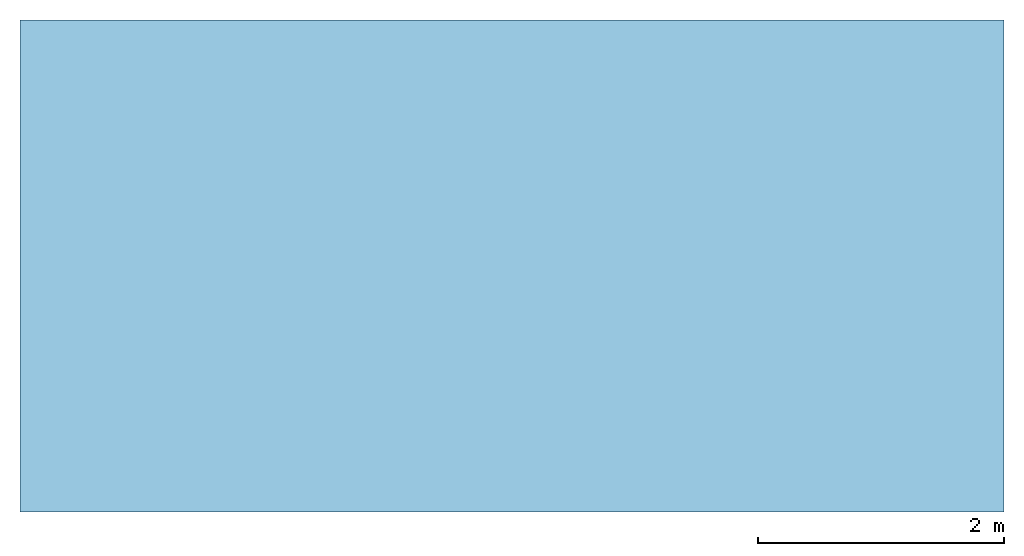
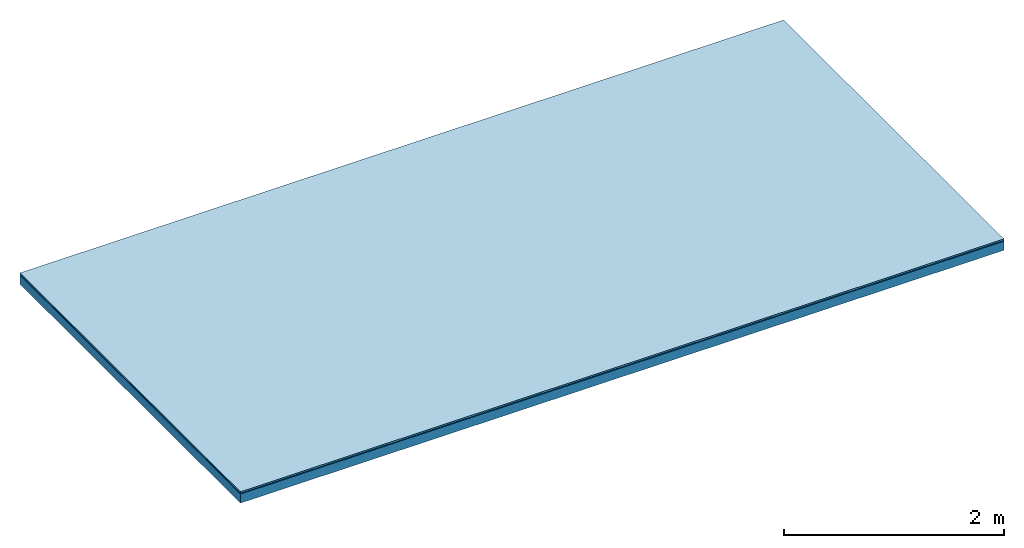
# One storey: 3 plates, 1 member, 1 element without a shape of its own.
"""IFC4 building model written with IfcOpenShell, lengths in metres."""

from ifc_helpers import new_model, si_unit, derived_unit, direction, frame, frame_2d, origin, origin_with_axes, place, context, project, spatial, rectangle, extrude, material, layer, layer_set, type_object, element, aggregate, save


model = new_model("IFC4")

# Units and contexts
plan_context = context("Plan", 3, precision=1e-05, world=origin(), true_north=direction((0.0, 1.0)))
model_context = context("Model", 3, precision=1e-05, world=origin(), true_north=direction((0.0, 1.0)))
ifc_project = project(units=[si_unit("LENGTHUNIT", "METRE"), derived_unit("SOUNDPRESSUREUNIT", [(si_unit("PRESSUREUNIT", "PASCAL", prefix="MICRO"), 0)]), si_unit("ENERGYUNIT", "JOULE", prefix="MEGA"), si_unit("MASSUNIT", "GRAM", prefix="KILO"), derived_unit("THERMALTRANSMITTANCEUNIT", [(si_unit("POWERUNIT", "WATT"), 1), (si_unit("AREAUNIT", "SQUARE_METRE"), -1), (si_unit("THERMODYNAMICTEMPERATUREUNIT", "KELVIN"), -1)]), derived_unit("AREADENSITYUNIT", [(si_unit("MASSUNIT", "GRAM", prefix="KILO"), 1), (si_unit("AREAUNIT", "SQUARE_METRE"), -1)]), derived_unit("USERDEFINED", [(si_unit("ENERGYUNIT", "JOULE", prefix="MEGA"), 1), (si_unit("AREAUNIT", "SQUARE_METRE"), -1)])], contexts=[plan_context, model_context])

# Site, building, storey
site = spatial("IfcSite", under=ifc_project)
building_placement = place(None, origin())
building = spatial("IfcBuilding", under=site, at=building_placement)
storey_placement = place(building_placement, origin())
storey = spatial("IfcBuildingStorey", under=building, at=storey_placement)

# Slab, member, plates
ifc_material_1 = material(Category="11.013")
ifc_layer_1 = layer(ifc_material_1, 0.015, Name="Flooring")
ifc_material_2 = material(Name="Wood fiber generic product", Category="10.009")
ifc_layer_2 = layer(ifc_material_2, 0.01, Name="Impact sound insulation")
ifc_material_3 = material(Name="protection", Category="09.007")
ifc_layer_3 = layer(ifc_material_3, 0.0005, Name="Sub-floor")
ifc_material_4 = material(Name="no composite action")
ifc_layer_4 = layer(ifc_material_4, 0.0, Name="Bond")
ifc_layer_5 = layer(None, 0.1, Name="Supporting structure")
ifc_layer_set = layer_set([ifc_layer_1, ifc_layer_2, ifc_layer_3, ifc_layer_4, ifc_layer_5])
slab_type = type_object("IfcSlabType", Name="A2005", PredefinedType="NOTDEFINED", material=ifc_layer_set)
slab_placement = place(None, frame((0.0, 0.0, 0.0), z_axis=(0.0, 0.0, -1.0), x_axis=(1.0, 0.0, 0.0)))
slab = element("IfcSlab", 1, at=slab_placement, inside=storey, type_object=slab_type, material=ifc_layer_set, Name="Slab #1")
ifc_material_5 = material(Name="Solid timber panel")
member_placement = place(slab_placement, origin())
member = element("IfcMember", 2, at=member_placement, material=ifc_material_5, Name="Supporting structure", context=plan_context, shape_type="SweptSolid", body=[
    extrude(rectangle(XDim=1.0, YDim=0.1, at=frame_2d((0.5, 0.05), x_axis=(1.0, 0.0))), frame((0.0, 4.0, 0.0255), z_axis=(0.0, -1.0, 0.0), x_axis=(1.0, 0.0, 0.0)), (0.0, 0.0, 1.0), 4.0),
    extrude(rectangle(XDim=1.0, YDim=0.1, at=frame_2d((0.5, 0.05), x_axis=(1.0, 0.0))), frame((1.0, 4.0, 0.0255), z_axis=(0.0, -1.0, 0.0), x_axis=(1.0, 0.0, 0.0)), (0.0, 0.0, 1.0), 4.0),
    extrude(rectangle(XDim=1.0, YDim=0.1, at=frame_2d((0.5, 0.05), x_axis=(1.0, 0.0))), frame((2.0, 4.0, 0.0255), z_axis=(0.0, -1.0, 0.0), x_axis=(1.0, 0.0, 0.0)), (0.0, 0.0, 1.0), 4.0),
    extrude(rectangle(XDim=1.0, YDim=0.1, at=frame_2d((0.5, 0.05), x_axis=(1.0, 0.0))), frame((3.0, 4.0, 0.0255), z_axis=(0.0, -1.0, 0.0), x_axis=(1.0, 0.0, 0.0)), (0.0, 0.0, 1.0), 4.0),
    extrude(rectangle(XDim=1.0, YDim=0.1, at=frame_2d((0.5, 0.05), x_axis=(1.0, 0.0))), frame((4.0, 4.0, 0.0255), z_axis=(0.0, -1.0, 0.0), x_axis=(1.0, 0.0, 0.0)), (0.0, 0.0, 1.0), 4.0),
    extrude(rectangle(XDim=1.0, YDim=0.1, at=frame_2d((0.5, 0.05), x_axis=(1.0, 0.0))), frame((5.0, 4.0, 0.0255), z_axis=(0.0, -1.0, 0.0), x_axis=(1.0, 0.0, 0.0)), (0.0, 0.0, 1.0), 4.0),
    extrude(rectangle(XDim=1.0, YDim=0.1, at=frame_2d((0.5, 0.05), x_axis=(1.0, 0.0))), frame((6.0, 4.0, 0.0255), z_axis=(0.0, -1.0, 0.0), x_axis=(1.0, 0.0, 0.0)), (0.0, 0.0, 1.0), 4.0),
    extrude(rectangle(XDim=1.0, YDim=0.1, at=frame_2d((0.5, 0.05), x_axis=(1.0, 0.0))), frame((7.0, 4.0, 0.0255), z_axis=(0.0, -1.0, 0.0), x_axis=(1.0, 0.0, 0.0)), (0.0, 0.0, 1.0), 4.0),
])
plate_1_placement = place(slab_placement, origin())
plate_1 = element("IfcPlate", 3, at=plate_1_placement, material=ifc_material_1, Name="Flooring", context=plan_context, shape_type="SweptSolid", body=[
    extrude(rectangle(XDim=8.0, YDim=4.0, at=frame_2d((4.0, 2.0), x_axis=(1.0, 0.0))), origin_with_axes(), (0.0, 0.0, 1.0), 0.015),
])
plate_2_placement = place(slab_placement, origin())
plate_2 = element("IfcPlate", 4, at=plate_2_placement, material=ifc_material_2, Name="Impact sound insulation", context=plan_context, shape_type="SweptSolid", body=[
    extrude(rectangle(XDim=8.0, YDim=4.0, at=frame_2d((4.0, 2.0), x_axis=(1.0, 0.0))), frame((0.0, 0.0, 0.015), z_axis=(0.0, 0.0, 1.0), x_axis=(1.0, 0.0, 0.0)), (0.0, 0.0, 1.0), 0.01),
])
plate_3_placement = place(slab_placement, origin())
plate_3 = element("IfcPlate", 5, at=plate_3_placement, material=ifc_material_3, Name="Sub-floor", context=plan_context, shape_type="SweptSolid", body=[
    extrude(rectangle(XDim=8.0, YDim=4.0, at=frame_2d((4.0, 2.0), x_axis=(1.0, 0.0))), frame((0.0, 0.0, 0.025), z_axis=(0.0, 0.0, 1.0), x_axis=(1.0, 0.0, 0.0)), (0.0, 0.0, 1.0), 0.0005),
])
aggregate(slab, [plate_1, plate_2, plate_3, member])

save(model, "model.ifc")
